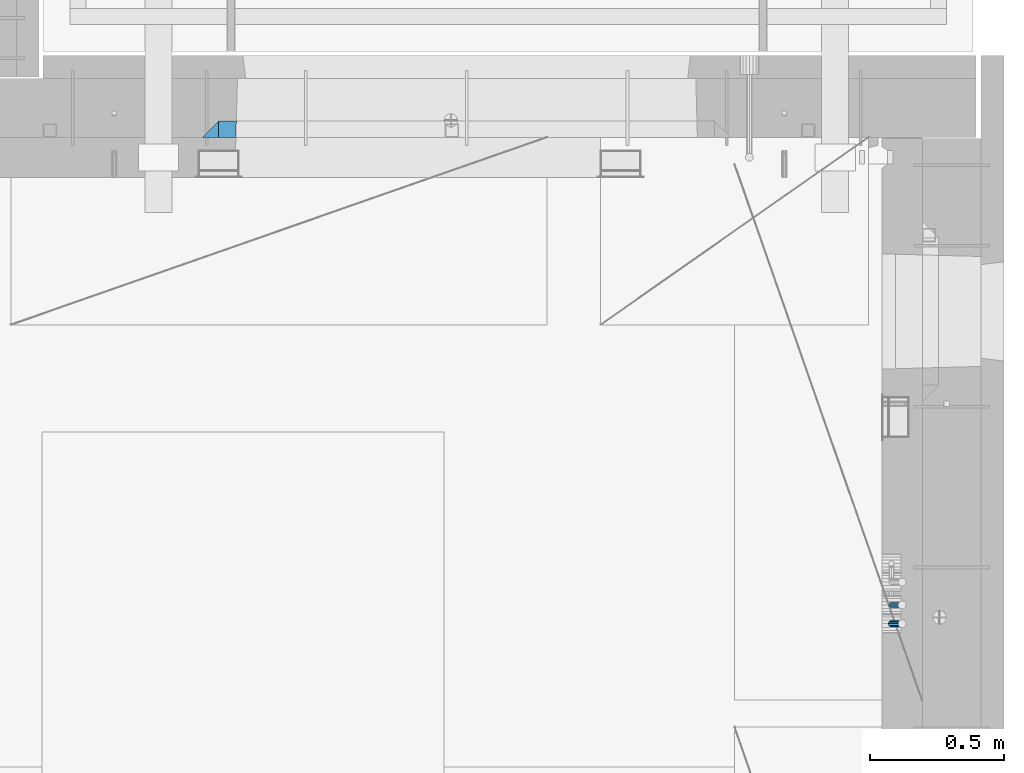
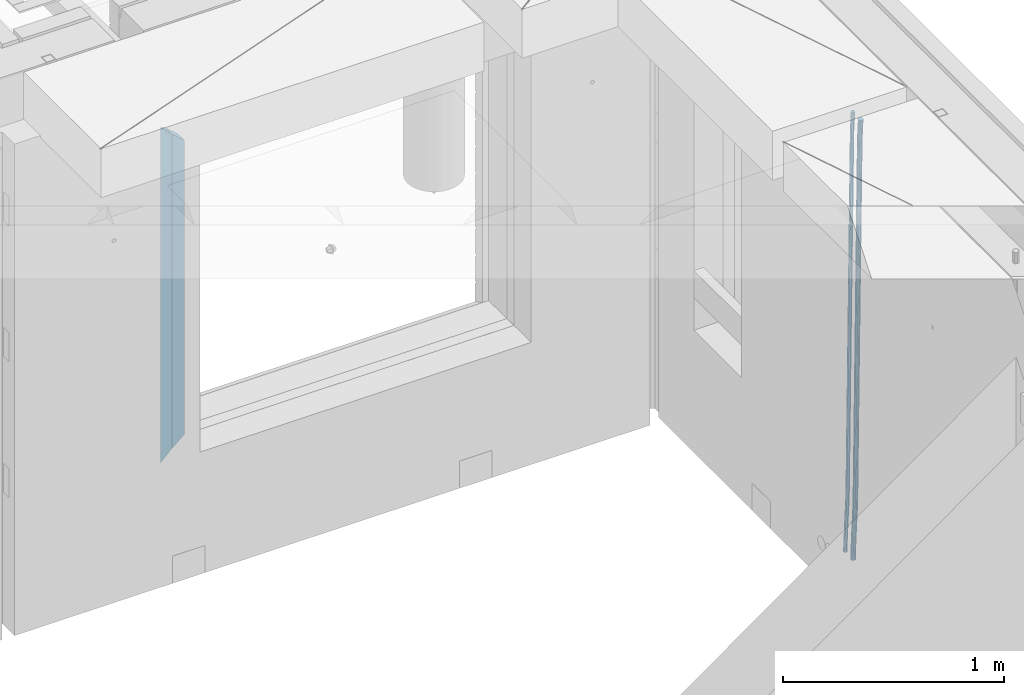
# One storey, part 127 of 334: 4 beams, 2 elements without a shape of their own.
"""IFC2X3 building model written with IfcOpenShell, lengths in millimetres."""

from ifc_helpers import new_model, si_unit, frame, origin_with_axes, place, context, subcontext, project, spatial, faceted_brep, material, type_object, element, aggregate, save


model = new_model("IFC2X3")

# Units and contexts
model_context = context("Model", 3, precision=1e-05, world=origin_with_axes())
body_context = subcontext(model_context, "Body", "Model", "MODEL_VIEW")
ifc_project = project(units=[si_unit("LENGTHUNIT", "METRE", prefix="MILLI"), si_unit("AREAUNIT", "SQUARE_METRE"), si_unit("VOLUMEUNIT", "CUBIC_METRE"), si_unit("MASSUNIT", "GRAM", prefix="KILO"), si_unit("TIMEUNIT", "SECOND"), si_unit("PLANEANGLEUNIT", "RADIAN"), si_unit("SOLIDANGLEUNIT", "STERADIAN"), si_unit("THERMODYNAMICTEMPERATUREUNIT", "DEGREE_CELSIUS"), si_unit("LUMINOUSINTENSITYUNIT", "LUMEN")], contexts=[model_context])

# Site, building, storey
site_placement = place(None, origin_with_axes())
site = spatial("IfcSite", under=ifc_project, at=site_placement, CompositionType="ELEMENT")
building_placement = place(site_placement, origin_with_axes())
building = spatial("IfcBuilding", under=site, at=building_placement, CompositionType="ELEMENT")
storey_placement = place(building_placement, origin_with_axes())
storey = spatial("IfcBuildingStorey", under=building, at=storey_placement, Name="3", CompositionType="ELEMENT", Elevation=0.0)

# Assembly, beams
assembly_1_placement = place(storey_placement, origin_with_axes())
assembly_1 = element("IfcElementAssembly", 1, at=assembly_1_placement, inside=storey, AssemblyPlace="NOTDEFINED", PredefinedType="REINFORCEMENT_UNIT")
ifc_material_1 = material()
beam_type_1 = type_object("IfcBeamType", Name="D20", PredefinedType="NOTDEFINED")
beam_1_placement = place(assembly_1_placement, frame((34944.9999977209, 18835.0002441367, 87990.0), z_axis=(0.999642804629538, 0.000205762999925497, -0.0267249099901003), x_axis=(0.0267249109941254, -4.30000210532798e-08, 0.999642825779465)))
beam_1 = element("IfcBeam", 2, at=beam_1_placement, type_object=beam_type_1, material=ifc_material_1, Name="JM20", ObjectType="D20", context=body_context, shape_type="Brep", body=[
    faceted_brep([(0.0, -10.0, 0.0), (-4.19531716033816e-08, -7.07106781186667, -7.07106781187031), (60.4266690400545, -7.0710677960451, -7.07106780570757), (60.4266690441291, -9.99999998418934, 6.15546014159918e-09), (0.0, 0.0, -10.0), (60.426669036824, 1.58106558956206e-08, -9.99999999384454), (4.196772351861e-08, 7.07106781186303, -7.07106781186667), (60.4266690363438, 7.07106782768096, -7.07106780570757), (0.0, 10.0, 0.0), (60.4266690388904, 10.0000000158179, 6.15182216279209e-09), (4.196772351861e-08, 7.07106781185939, 7.07106781185939), (60.4266690429649, 7.07106782768096, 7.07106781802577), (0.0, 0.0, 10.0), (60.4266690461809, 1.58179318532348e-08, 10.0000000061555), (-4.19531716033816e-08, -7.07106781187031, 7.07106781185939), (60.4266690466611, -7.07106779605238, 7.07106781802213), (61.0378400410118, -7.07106779588503, -7.07106780564936), (60.991799419251, -9.99999998403655, 6.21366780251265e-09), (61.0569027789461, 1.5985278878361e-08, -9.99999999378269), (61.0378209396877, 7.07106782784831, -7.07106780564936), (60.9917724058905, 10.0000000159635, 6.21366780251265e-09), (60.9457317841297, 7.07106782781193, 7.0710678180767), (60.9266690461809, 1.59488990902901e-08, 10.0000000062028), (60.9457508854539, -7.07106779591413, 7.0710678180767), (61.6489592143771, -7.07106614513759, -7.06310863441468), (61.5568818710308, -9.9999984576425, 0.00735959856683621), (61.6870830769039, 1.71821739058942e-06, -9.99179257185824), (61.6489210170112, 7.07106947854481, -7.06310888312146), (61.556827851804, 10.0000015422847, 0.00735924683976918), (61.4647505084577, 7.07106922979438, 7.07782747982128), (61.4266266459163, 1.36643211590126e-06, 10.0065114172685), (61.464788705809, -7.07106639389531, 7.07782772852806), (176.543135720174, -7.07075579406956, -5.56673531796696), (176.451058376813, -9.99968810657447, 1.50373291501455), (176.581259582701, 0.000312069292704109, -8.49541925541052), (176.543097522794, 7.07137982961285, -5.56673556667374), (176.451004357587, 10.00031189336, 1.50373256329476), (176.35892701424, 7.07137958085514, 8.57420079627263), (176.320803151699, 0.000311717507429421, 11.5028847337162), (176.358965211621, -7.07075604281999, 8.57420104497578), (177.098753836006, -7.07075429323595, -5.55949898843028), (176.98362511232, -9.99968666800123, 1.510669025065), (177.146421932586, 0.000313595905026887, -8.48805862247536), (177.098706077581, 7.07138133041735, -5.55949936166144), (176.983557571715, 10.0003133318824, 1.51066849724157), (176.868428848029, 7.07138095712435, 8.58083651073321), (176.820760751449, 0.000313067976094317, 11.5093961447819), (176.868476606425, -7.07075466652896, 8.58083688396073), (177.654312950661, -7.07075204110879, -5.54863964998367), (177.516135294456, -9.99968450931192, 1.52107783331303), (177.711524267797, 0.000315886711177882, -8.47701274570863), (177.654255632195, 7.07138358250813, -5.54864021007961), (177.516054233929, 10.0003154905207, 1.5210770412159), (177.377876577739, 7.0713830223176, 8.59079452451624), (177.320665260588, 0.000315094497636892, 11.5191676202448), (177.377933896176, -7.07075260129932, 8.59079508461218), (299.436796249574, -7.07025836271714, -3.1681962331204), (299.298618593355, -9.99919083092027, 3.90152125031091), (299.494007566798, 0.000809565110102994, -6.09656932889993), (299.436738931283, 7.07187726089978, -3.16819679320906), (299.298537533061, 10.0008091689197, 3.90152045822106), (299.160359876842, 7.07187670072017, 10.9712379416487), (299.103148559603, 0.000808772889286047, 13.8996110374392), (299.160417195119, -7.07025892290039, 10.9712385017483), (299.98743051647, -7.07025613056248, -3.15743315966392), (299.971788958996, -9.99918809853989, 3.91467979818117), (299.993912075952, 0.000811591617093654, -6.08679785393178), (299.987423933868, 7.07187949325817, -3.1574327280432), (299.971753863239, 10.0008119014747, 3.91467990454839), (299.95611230444, 7.07187992653053, 10.9867922621015), (299.949630744944, 0.000812204350950196, 13.9161569563694), (299.956118887014, -7.07025569729012, 10.9867918304735), (300.538107039494, -7.07025785017686, -3.16575821840888), (300.644985195438, -9.99919020432935, 3.90450175465594), (300.493854948218, 0.000810030429420294, -6.09435592770024), (300.538151196495, 7.071877773491, -3.16575855385963), (300.645047642858, 10.0008097955724, 3.90450128024895), (300.751925798773, 7.07187744142357, 10.9747612533101), (300.796177890064, 0.000809560813650023, 13.9033589625978), (300.751881641787, -7.07025818224065, 10.9747615887682), (2293.36490490142, -7.07648090940347, -33.2930642912361), (2293.47178305736, -10.0054132635523, -26.2228043181785), (2293.32065281013, -0.00541302880083094, -36.2216620005347), (2293.36494905842, 7.06565471425711, -33.2930646266868), (2293.47184550477, 9.99458673634581, -26.2228047925819), (2293.57872366071, 7.06565438219332, -19.1525448195243), (2293.62297575199, -0.00541349841296324, -16.2239471102366), (2293.57867950371, -7.0764812414709, -19.1525444840736), (2294.0658245362, -7.07648309818615, -33.3036607065333), (2294.05312277409, -10.0054150789219, -26.2315929392535), (2294.10928714235, -0.00541549149056664, -36.2335844756526), (2294.15805078732, 7.06565223761572, -33.3050546393533), (2294.18355038921, 9.99458451388637, -26.2335642579346), (2294.17084862708, 7.06565253314329, -19.1614964906439), (2294.12738602093, -0.00541507354500936, -16.2315727215355), (2294.07862237596, -7.07648280265857, -19.1601025578348), (2294.76670261032, -7.08562269121467, -33.294332712383), (2294.63442802057, -10.0129954178956, -26.2238563411993), (2294.89787471293, -0.0156988342423574, -36.2230891548279), (2294.95110548967, 7.05531064255774, -33.2944998654275), (2294.89521307347, 9.98530428734011, -26.2240927312887), (2294.76293848372, 7.0579315606592, -19.1536163601049), (2294.63176638114, -0.0119922963167483, -16.2248599176673), (2294.57853560438, -7.08300177311321, -19.1534492070678), (2316.52657204497, -7.36937582653991, -33.0047303660212), (2316.39429745522, -10.2967485532172, -25.9342539948302), (2316.65774414754, -0.299451969567599, -35.9334868084661), (2316.7109749243, 6.7715575072325, -33.0048975190657), (2316.65508250811, 9.70155115201487, -25.9344903849269), (2316.52280791836, 6.7741784253376, -18.8640140137468), (2316.39163581574, -0.295745431634714, -15.9352575713092), (2316.33840503903, -7.36675490843481, -18.863846860706), (2317.16202064224, -7.37766220584308, -32.9962731735213), (2317.05438744847, -10.3053562613532, -25.9254688497131), (2317.23607125619, -0.306993473008333, -35.925789846493), (2317.23316144495, 6.76474808850253, -32.9979477328052), (2317.15499573652, 9.6950321815566, -25.9278370341635), (2317.04736254275, 6.7673381260538, -18.8570327103698), (2316.97331192881, -0.303330606784584, -15.9275160373909), (2316.97622174003, -7.37507216829545, -18.8553581510787), (2317.79752306276, -7.37578610372293, -32.9880110666527), (2317.71453320107, -10.3033876998124, -25.9168792378296), (2317.81444760226, -0.305295583297266, -35.918287695793), (2317.75539265381, 6.76628640723357, -32.9911928173897), (2317.65495180529, 9.69652304524061, -25.9213789128698), (2317.5719619436, 6.76892144914746, -18.8502470840467), (2317.55503740412, -0.301569071270933, -15.9199704549137), (2317.61409235255, -7.3731510618054, -18.847065333317), (2417.8183084176, -7.07752398473531, -31.6906369377139), (2417.73531855589, -10.0051255808248, -24.6195051088798), (2417.83523295709, -0.007033464313281, -34.6209135668432), (2417.77617800863, 7.06454852621755, -31.6938186884508), (2417.67573716014, 9.99478516423187, -24.6240047839383), (2417.59274729842, 7.06718356813872, -17.5528729551006), (2417.57582275895, -0.00330695228694822, -14.6225963259749), (2417.6348777074, -7.07488894281778, -17.5496912043673)], [[[0, 1, 2, 3]], [[1, 4, 5, 2]], [[4, 6, 7, 5]], [[6, 8, 9, 7]], [[8, 10, 11, 9]], [[10, 12, 13, 11]], [[12, 14, 15, 13]], [[14, 0, 3, 15]], [[14, 12, 10, 8, 6, 4, 1, 0]], [[3, 2, 16, 17]], [[2, 5, 18, 16]], [[5, 7, 19, 18]], [[7, 9, 20, 19]], [[9, 11, 21, 20]], [[11, 13, 22, 21]], [[13, 15, 23, 22]], [[15, 3, 17, 23]], [[17, 16, 24, 25]], [[16, 18, 26, 24]], [[18, 19, 27, 26]], [[19, 20, 28, 27]], [[20, 21, 29, 28]], [[21, 22, 30, 29]], [[22, 23, 31, 30]], [[23, 17, 25, 31]], [[25, 24, 32, 33]], [[24, 26, 34, 32]], [[26, 27, 35, 34]], [[27, 28, 36, 35]], [[28, 29, 37, 36]], [[29, 30, 38, 37]], [[30, 31, 39, 38]], [[31, 25, 33, 39]], [[33, 32, 40, 41]], [[32, 34, 42, 40]], [[34, 35, 43, 42]], [[35, 36, 44, 43]], [[36, 37, 45, 44]], [[37, 38, 46, 45]], [[38, 39, 47, 46]], [[39, 33, 41, 47]], [[41, 40, 48, 49]], [[40, 42, 50, 48]], [[42, 43, 51, 50]], [[43, 44, 52, 51]], [[44, 45, 53, 52]], [[45, 46, 54, 53]], [[46, 47, 55, 54]], [[47, 41, 49, 55]], [[49, 48, 56, 57]], [[48, 50, 58, 56]], [[50, 51, 59, 58]], [[51, 52, 60, 59]], [[52, 53, 61, 60]], [[53, 54, 62, 61]], [[54, 55, 63, 62]], [[55, 49, 57, 63]], [[57, 56, 64, 65]], [[56, 58, 66, 64]], [[58, 59, 67, 66]], [[59, 60, 68, 67]], [[60, 61, 69, 68]], [[61, 62, 70, 69]], [[62, 63, 71, 70]], [[63, 57, 65, 71]], [[65, 64, 72, 73]], [[64, 66, 74, 72]], [[66, 67, 75, 74]], [[67, 68, 76, 75]], [[68, 69, 77, 76]], [[69, 70, 78, 77]], [[70, 71, 79, 78]], [[71, 65, 73, 79]], [[73, 72, 80, 81]], [[72, 74, 82, 80]], [[74, 75, 83, 82]], [[75, 76, 84, 83]], [[76, 77, 85, 84]], [[77, 78, 86, 85]], [[78, 79, 87, 86]], [[79, 73, 81, 87]], [[81, 80, 88, 89]], [[80, 82, 90, 88]], [[82, 83, 91, 90]], [[83, 84, 92, 91]], [[84, 85, 93, 92]], [[85, 86, 94, 93]], [[86, 87, 95, 94]], [[87, 81, 89, 95]], [[89, 88, 96, 97]], [[88, 90, 98, 96]], [[90, 91, 99, 98]], [[91, 92, 100, 99]], [[92, 93, 101, 100]], [[93, 94, 102, 101]], [[94, 95, 103, 102]], [[95, 89, 97, 103]], [[97, 96, 104, 105]], [[96, 98, 106, 104]], [[98, 99, 107, 106]], [[99, 100, 108, 107]], [[100, 101, 109, 108]], [[101, 102, 110, 109]], [[102, 103, 111, 110]], [[103, 97, 105, 111]], [[105, 104, 112, 113]], [[104, 106, 114, 112]], [[106, 107, 115, 114]], [[107, 108, 116, 115]], [[108, 109, 117, 116]], [[109, 110, 118, 117]], [[110, 111, 119, 118]], [[111, 105, 113, 119]], [[113, 112, 120, 121]], [[112, 114, 122, 120]], [[114, 115, 123, 122]], [[115, 116, 124, 123]], [[116, 117, 125, 124]], [[117, 118, 126, 125]], [[118, 119, 127, 126]], [[119, 113, 121, 127]], [[121, 120, 128, 129]], [[120, 122, 130, 128]], [[122, 123, 131, 130]], [[123, 124, 132, 131]], [[124, 125, 133, 132]], [[125, 126, 134, 133]], [[126, 127, 135, 134]], [[127, 121, 129, 135]], [[130, 131, 132, 133, 134, 135, 129, 128]]]),
])
beam_type_2 = type_object("IfcBeamType", Name="D25", PredefinedType="NOTDEFINED")
beam_2_placement = place(assembly_1_placement, frame((34944.9999977209, 18765.0002441367, 87990.0), z_axis=(0.999642804629538, 0.000205762999925497, -0.0267249099901003), x_axis=(0.0267249109941254, -4.30000210532798e-08, 0.999642825779465)))
beam_2 = element("IfcBeam", 3, at=beam_2_placement, type_object=beam_type_2, material=ifc_material_1, Name="JM25", ObjectType="D25", context=body_context, shape_type="Brep", body=[
    faceted_brep([(-7.41420080885291e-08, -12.5, -3.63797880709171e-12), (-6.42030499875546e-08, -10.8253175473074, -6.25000000000364), (60.4103898235917, -10.8253175318459, -6.2499999938409), (60.4103898269532, -12.4999999845422, 6.16273609921336e-09), (-3.70782800018787e-08, -6.25000000000364, -10.8253175473074), (60.4103898202884, -6.24999998454587, -10.8253175411446), (-1.45519152283669e-11, -3.63797880709171e-12, -12.5), (60.4103898179019, 1.54577719513327e-08, -12.4999999938373), (3.70637280866504e-08, 6.25, -10.8253175473074), (60.410389817087, 6.25000001545777, -10.825317541141), (6.42030499875546e-08, 10.8253175473001, -6.25000000000364), (60.410389818062, 10.8253175627578, -6.24999999383726), (7.41420080885291e-08, 12.4999999999927, 0.0), (60.4103898205503, 12.5000000154541, 6.16273609921336e-09), (6.42176019027829e-08, 10.8253175473001, 6.24999999999636), (60.4103898238973, 10.8253175627651, 6.2500000061591), (3.70928319171071e-08, 6.24999999999636, 10.8253175473037), (60.4103898272151, 6.25000001546141, 10.8253175534664), (1.45519152283669e-11, -3.63797880709171e-12, 12.4999999999964), (60.4103898296162, 1.54541339725256e-08, 12.5000000061591), (-3.7049176171422e-08, -6.25000000000364, 10.8253175473001), (60.4103898304165, -6.24999998454587, 10.8253175534701), (-6.41884980723262e-08, -10.8253175473074, 6.25), (60.4103898294561, -10.8253175318459, 6.25000000616637), (61.0324985728803, -10.8253175316895, -6.24999999377542), (60.991802792938, -12.4999999843931, 6.22458173893392e-09), (61.0622854283865, -6.24999998437852, -10.8253175410755), (61.0731819955545, 1.5628756955266e-08, -12.4999999937718), (61.0622685480339, 6.25000001562512, -10.8253175410791), (61.032469335245, 10.8253175629216, -6.24999999377178), (60.9917690322181, 12.5000000156033, 6.22458173893392e-09), (60.9510732522613, 10.8253175629034, 6.25000000621731), (60.9212863967696, 6.25000001558874, 10.8253175535247), (60.9103898296162, 1.55814632307738e-08, 12.5000000062137), (60.9213032771368, -6.24999998441126, 10.8253175535174), (60.9511024898966, -10.8253175317113, 6.25000000621731), (61.6545545670233, -10.8253158516927, -6.24189838219536), (61.573166454793, -12.499998414296, 0.00757164385504439), (61.7141257553885, -6.24999822394238, -10.8168280205282), (61.7359179680789, 1.80548886419274e-06, -12.491368569139), (61.7140919992817, 6.25000177601396, -10.8168282403167), (61.6544960997562, 10.8253192428383, -6.2418987628771), (61.5730989426083, 12.5000015856094, 0.0075712042817031), (61.4917108303925, 10.8253190230062, 6.25704123032847), (61.4321396420273, 6.25000139525582, 10.8319708686649), (61.4103474293224, 1.36582457344048e-06, 12.5065114172721), (61.4321733981196, -6.24999860470052, 10.8319710884571), (61.4917692976451, -10.8253160715249, 6.25704161101385), (176.524302641745, -10.8250056210964, -4.74584321979273), (176.442914529529, -12.4996881836996, 1.50362680625403), (176.583873830095, -6.24968799334965, -9.3207728581292), (176.605666042786, 0.000312036081595579, -10.9953134067364), (176.583840074018, 6.25031200660669, -9.32077307791769), (176.524244174492, 10.8256294734347, -4.74584360047811), (176.44284701733, 12.5003118162058, 1.50362636668069), (176.361458905099, 10.8256292535989, 7.75309639272746), (176.301887716749, 6.25031162585219, 12.3280260310676), (176.280095504058, 0.000311596420942806, 14.0025665796711), (176.301921472827, -6.24968837410415, 12.3280262508561), (176.361517372367, -10.8250058409321, 7.75309677341284), (177.085397012124, -10.8250041057399, -4.73853556792164), (176.983633547483, -12.4996867233749, 1.51066909103247), (177.159881729676, -6.24968643771717, -9.31327097355097), (177.187129580227, 0.000313606451527448, -10.987740468332), (177.159839524218, 6.25031356221734, -9.31327130338468), (177.085323910098, 10.8256309887511, -4.73853613920801), (176.983549136537, 12.5003132764905, 1.51066843136869), (176.881785671867, 10.8256306588555, 7.7598730903228), (176.80730095433, 6.25031299082912, 12.3346084959521), (176.780053103794, 0.000312946667690994, 14.0090779907332), (176.807343159802, -6.2496870091054, 12.3346088257895), (176.881858773908, -10.8250044356355, 7.7598736616128), (177.646431799818, -10.8250018318176, -4.72756919822132), (177.524295146417, -12.4996845320202, 1.52123723245313), (177.735828462886, -6.24968410334986, -9.30201312475765), (177.768531371941, 0.00031596292683389, -10.9763759912421), (177.735777808921, 6.25031589654827, -9.30201361973741), (177.646344064575, 10.8256332626152, -4.72757005553649), (177.524193838486, 12.5003154677688, 1.52123624250817), (177.402057185071, 10.8256327675663, 7.77004267317898), (177.312660521988, 6.2503150390985, 12.3444865997226), (177.279957612933, 0.00031497282179771, 14.0188494661961), (177.312711175953, -6.24968496079964, 12.3444870946951), (177.402144920314, -10.8250023268702, 7.77004353049415), (299.377443161706, -10.8245084454466, -2.34813158632096), (299.255306508276, -12.4991911456491, 3.90067484435349), (299.466839824803, -6.24919071697514, -6.92257551286093), (299.499542733873, 0.0008093492979242, -8.59693837933446), (299.466789170867, 6.250809282923, -6.92257600783341), (299.377355426492, 10.8261266489935, -2.34813244364341), (299.255205200388, 12.5008088541435, 3.90067385440125), (299.133068546944, 10.826126153941, 10.1494802850757), (299.043671883861, 6.25080842546959, 14.7239242116229), (299.010968974762, 0.000808359200163977, 16.3982870780892), (299.043722537797, -6.24919157442127, 14.7239247065918), (299.133156282158, -10.8245089404954, 10.1494811423981), (299.98561436501, -10.8245059804758, -2.33624385599614), (299.97179243555, -12.4991882411778, 3.91467976726199), (299.995742293278, -6.24918857328521, -6.91223722345239), (299.999447243041, 0.000811375455668895, -8.58716690387519), (299.995736475976, 6.25081142679483, -6.91223684201032), (299.985604289133, 10.8261291142808, -2.33624319533556), (299.971750386685, 12.5008117588586, 3.91467993563856), (299.957928457196, 10.8261294971744, 10.1656035610831), (299.947800528913, 6.25081208998381, 14.7415969285394), (299.944095579151, 0.00081214124293183, 16.4165266089549), (299.947806346216, -6.24918791008895, 14.7415965471009), (299.957938533058, -10.8245055975785, 10.1656029004225), (300.593832239858, -10.8245078794353, -2.34543881707941), (300.688302931099, -12.4991904788549, 3.90384712594823), (300.524685350189, -6.24919022474205, -6.92023371784308), (300.499390115292, 0.000809814544481924, -8.59472497713432), (300.524724372954, 6.25080977519247, -6.92023401429469), (300.593899829313, 10.8261272150703, -2.34543933054374), (300.688380976673, 12.5008095210287, 3.90384653304136), (300.782851667915, 10.8261269216127, 10.1531324760799), (300.851998557599, 6.25080926691589, 14.7279273768363), (300.877293792495, 0.000809227632998955, 16.4024186361276), (300.851959534804, -6.24919073302226, 14.7279276732806), (300.782784078474, -10.8245081728965, 10.153132989537), (2293.32930409742, -10.8307295605009, -32.4713622331001), (2293.42377478865, -12.5054121599169, -26.2220762900724), (2293.26015720774, -6.2554119058077, -37.0461571338565), (2293.23486197284, -0.00541186651753378, -38.7206483931477), (2293.26019623051, 6.24458809413409, -37.0461574303008), (2293.32937168686, 10.8199055340046, -32.4713627465644), (2293.42385283421, 12.4945878399631, -26.2220768829684), (2293.51832352545, 10.8199052405434, -19.972790939948), (2293.58747041514, 6.24458758585388, -15.3979960391844), (2293.61276565003, -0.00541245343265473, -13.7235047798931), (2293.58743139236, -6.25541241408428, -15.3979957427327), (2293.51825593603, -10.8307298539585, -19.9727904264691), (2294.0420846676, -10.8307317859326, -32.4821379598216), (2294.03681932652, -12.5054140739521, -26.2313442200393), (2294.06778164886, -6.2554144273563, -37.0583666982457), (2294.10702478497, -0.00541458957013674, -38.7338336404937), (2294.14929890928, 6.24458531819619, -37.0595987724118), (2294.18327670435, 10.8199028679592, -32.4842719748667), (2294.1998538474, 12.4945854171456, -26.2338083683717), (2294.19458850632, 10.819903129126, -19.9830146285858), (2294.16889152506, 6.24458577054975, -15.4067858901581), (2294.12964838895, -0.0054140672327776, -13.7313189479173), (2294.08737426462, -6.2554139749991, -15.4055538159919), (2294.05339646956, -10.8307315247621, -19.9808806135297), (2294.75482297382, -10.84002603931, -32.4726521173216), (2294.64982751427, -12.513407826169, -26.2231856868602), (2294.87535820232, -6.26594539088183, -37.0476186524102), (2294.97913588268, -0.0167870967634371, -38.7222267036377), (2295.0383488692, 6.23299192477134, -37.0477663960555), (2295.03713108998, 10.8087684320271, -32.4729080168181), (2294.97580884799, 12.4844668051373, -26.2234811741473), (2294.87081338844, 10.8110850182784, -19.9740147436787), (2294.7502781599, 6.23700436985018, -15.3990482086047), (2294.64650047956, -0.0121539242718427, -13.7244401573698), (2294.58728749304, -6.26193294580662, -15.3989004649666), (2294.58850527227, -10.8377094530588, -19.9737588441894), (2316.44667268227, -11.1228921988077, -32.1839550346631), (2316.34167722271, -12.7962739856739, -25.9344886042054), (2316.56720791078, -6.54881155039038, -36.7589215697517), (2316.67098559113, -0.299653256264719, -38.4335296209792), (2316.73019857766, 5.95012576527006, -36.759069313397), (2316.72898079845, 10.5259022725259, -32.1842109341669), (2316.66765855643, 12.2016006456361, -25.9347840914961), (2316.56266309689, 10.5282188587698, -19.6853176610275), (2316.44212786836, 5.95413821035254, -15.1103511259389), (2316.33835018802, -0.295020083769487, -13.4357430747186), (2316.27913720149, -6.54479910530426, -15.1102033823008), (2316.28035498071, -11.1205756125637, -19.685061761531), (2317.13234804722, -11.1318335458927, -32.1748293731798), (2317.04181141085, -12.8054038787741, -25.9251705100723), (2317.2154741603, -6.5572650749491, -36.7502937866229), (2317.26891617525, -0.307450393454928, -38.4255717558117), (2317.27835434731, 5.94297770185585, -36.7517739018112), (2317.24125972588, 10.5192220504723, -32.1773930078925), (2317.16757178486, 12.1950816748285, -25.9281307404563), (2317.0770351485, 10.5215113419545, -19.6784718773561), (2316.99390903539, 5.94694287101083, -15.1030074639057), (2316.94046702047, -0.302871810494253, -13.4277294947169), (2316.9310288484, -6.55329990579412, -15.1015273487101), (2316.96812346982, -11.1295442544142, -19.6759082426288), (2317.81808136747, -11.1298054502913, -32.1659056455355), (2317.74200467508, -12.803315894289, -25.9160547315114), (2317.86379538118, -6.55536082026447, -36.7418676070083), (2317.8668976831, -0.305700748642266, -38.417815303761), (2317.82655701396, 5.94458339541234, -36.7446799039099), (2317.75358262347, 10.5207330230332, -32.1707766866384), (2317.66752794063, 12.1965725370646, -25.9216793252963), (2317.59145124823, 10.5230620930706, -19.6718284112721), (2317.54573723453, 5.94861746304377, -15.0958664497994), (2317.54263493262, -0.301042608574789, -13.4199187530394), (2317.58297560175, -6.55132675263303, -15.0930541529051), (2317.65594999224, -11.1274763802539, -19.6669573701693), (2417.81884292323, -10.831603083323, -30.8687911350135), (2417.74276623082, -12.505113527317, -24.618940220982), (2417.86455693691, -6.25715845329614, -35.4447530964935), (2417.86765923884, -0.00749838167394046, -37.1207007932499), (2417.82731856969, 6.24278576237703, -35.4475653933878), (2417.75434417921, 10.8189353900088, -30.8736621761236), (2417.66828949639, 12.494774904033, -24.6245648147851), (2417.59221280397, 10.8212644600353, -18.3747139007501), (2417.54649879028, 6.2468198300121, -13.79875193927), (2417.54339648837, -0.00284024161010166, -12.1228042425173), (2417.5837371575, -6.25312438566107, -13.795939642383), (2417.65671154798, -10.8292740132893, -18.3698428596399)], [[[0, 1, 2, 3]], [[1, 4, 5, 2]], [[4, 6, 7, 5]], [[6, 8, 9, 7]], [[8, 10, 11, 9]], [[10, 12, 13, 11]], [[12, 14, 15, 13]], [[14, 16, 17, 15]], [[16, 18, 19, 17]], [[18, 20, 21, 19]], [[20, 22, 23, 21]], [[22, 0, 3, 23]], [[22, 20, 18, 16, 14, 12, 10, 8, 6, 4, 1, 0]], [[3, 2, 24, 25]], [[2, 5, 26, 24]], [[5, 7, 27, 26]], [[7, 9, 28, 27]], [[9, 11, 29, 28]], [[11, 13, 30, 29]], [[13, 15, 31, 30]], [[15, 17, 32, 31]], [[17, 19, 33, 32]], [[19, 21, 34, 33]], [[21, 23, 35, 34]], [[23, 3, 25, 35]], [[25, 24, 36, 37]], [[24, 26, 38, 36]], [[26, 27, 39, 38]], [[27, 28, 40, 39]], [[28, 29, 41, 40]], [[29, 30, 42, 41]], [[30, 31, 43, 42]], [[31, 32, 44, 43]], [[32, 33, 45, 44]], [[33, 34, 46, 45]], [[34, 35, 47, 46]], [[35, 25, 37, 47]], [[37, 36, 48, 49]], [[36, 38, 50, 48]], [[38, 39, 51, 50]], [[39, 40, 52, 51]], [[40, 41, 53, 52]], [[41, 42, 54, 53]], [[42, 43, 55, 54]], [[43, 44, 56, 55]], [[44, 45, 57, 56]], [[45, 46, 58, 57]], [[46, 47, 59, 58]], [[47, 37, 49, 59]], [[49, 48, 60, 61]], [[48, 50, 62, 60]], [[50, 51, 63, 62]], [[51, 52, 64, 63]], [[52, 53, 65, 64]], [[53, 54, 66, 65]], [[54, 55, 67, 66]], [[55, 56, 68, 67]], [[56, 57, 69, 68]], [[57, 58, 70, 69]], [[58, 59, 71, 70]], [[59, 49, 61, 71]], [[61, 60, 72, 73]], [[60, 62, 74, 72]], [[62, 63, 75, 74]], [[63, 64, 76, 75]], [[64, 65, 77, 76]], [[65, 66, 78, 77]], [[66, 67, 79, 78]], [[67, 68, 80, 79]], [[68, 69, 81, 80]], [[69, 70, 82, 81]], [[70, 71, 83, 82]], [[71, 61, 73, 83]], [[73, 72, 84, 85]], [[72, 74, 86, 84]], [[74, 75, 87, 86]], [[75, 76, 88, 87]], [[76, 77, 89, 88]], [[77, 78, 90, 89]], [[78, 79, 91, 90]], [[79, 80, 92, 91]], [[80, 81, 93, 92]], [[81, 82, 94, 93]], [[82, 83, 95, 94]], [[83, 73, 85, 95]], [[85, 84, 96, 97]], [[84, 86, 98, 96]], [[86, 87, 99, 98]], [[87, 88, 100, 99]], [[88, 89, 101, 100]], [[89, 90, 102, 101]], [[90, 91, 103, 102]], [[91, 92, 104, 103]], [[92, 93, 105, 104]], [[93, 94, 106, 105]], [[94, 95, 107, 106]], [[95, 85, 97, 107]], [[97, 96, 108, 109]], [[96, 98, 110, 108]], [[98, 99, 111, 110]], [[99, 100, 112, 111]], [[100, 101, 113, 112]], [[101, 102, 114, 113]], [[102, 103, 115, 114]], [[103, 104, 116, 115]], [[104, 105, 117, 116]], [[105, 106, 118, 117]], [[106, 107, 119, 118]], [[107, 97, 109, 119]], [[109, 108, 120, 121]], [[108, 110, 122, 120]], [[110, 111, 123, 122]], [[111, 112, 124, 123]], [[112, 113, 125, 124]], [[113, 114, 126, 125]], [[114, 115, 127, 126]], [[115, 116, 128, 127]], [[116, 117, 129, 128]], [[117, 118, 130, 129]], [[118, 119, 131, 130]], [[119, 109, 121, 131]], [[121, 120, 132, 133]], [[120, 122, 134, 132]], [[122, 123, 135, 134]], [[123, 124, 136, 135]], [[124, 125, 137, 136]], [[125, 126, 138, 137]], [[126, 127, 139, 138]], [[127, 128, 140, 139]], [[128, 129, 141, 140]], [[129, 130, 142, 141]], [[130, 131, 143, 142]], [[131, 121, 133, 143]], [[133, 132, 144, 145]], [[132, 134, 146, 144]], [[134, 135, 147, 146]], [[135, 136, 148, 147]], [[136, 137, 149, 148]], [[137, 138, 150, 149]], [[138, 139, 151, 150]], [[139, 140, 152, 151]], [[140, 141, 153, 152]], [[141, 142, 154, 153]], [[142, 143, 155, 154]], [[143, 133, 145, 155]], [[145, 144, 156, 157]], [[144, 146, 158, 156]], [[146, 147, 159, 158]], [[147, 148, 160, 159]], [[148, 149, 161, 160]], [[149, 150, 162, 161]], [[150, 151, 163, 162]], [[151, 152, 164, 163]], [[152, 153, 165, 164]], [[153, 154, 166, 165]], [[154, 155, 167, 166]], [[155, 145, 157, 167]], [[157, 156, 168, 169]], [[156, 158, 170, 168]], [[158, 159, 171, 170]], [[159, 160, 172, 171]], [[160, 161, 173, 172]], [[161, 162, 174, 173]], [[162, 163, 175, 174]], [[163, 164, 176, 175]], [[164, 165, 177, 176]], [[165, 166, 178, 177]], [[166, 167, 179, 178]], [[167, 157, 169, 179]], [[169, 168, 180, 181]], [[168, 170, 182, 180]], [[170, 171, 183, 182]], [[171, 172, 184, 183]], [[172, 173, 185, 184]], [[173, 174, 186, 185]], [[174, 175, 187, 186]], [[175, 176, 188, 187]], [[176, 177, 189, 188]], [[177, 178, 190, 189]], [[178, 179, 191, 190]], [[179, 169, 181, 191]], [[181, 180, 192, 193]], [[180, 182, 194, 192]], [[182, 183, 195, 194]], [[183, 184, 196, 195]], [[184, 185, 197, 196]], [[185, 186, 198, 197]], [[186, 187, 199, 198]], [[187, 188, 200, 199]], [[188, 189, 201, 200]], [[189, 190, 202, 201]], [[190, 191, 203, 202]], [[191, 181, 193, 203]], [[194, 195, 196, 197, 198, 199, 200, 201, 202, 203, 193, 192]]]),
])
aggregate(assembly_1, [beam_1, beam_2])

assembly_2_placement = place(storey_placement, origin_with_axes())
assembly_2 = element("IfcElementAssembly", 4, at=assembly_2_placement, inside=storey, AssemblyPlace="NOTDEFINED", PredefinedType="REINFORCEMENT_UNIT")
ifc_material_2 = material(Name="CONCRETE/C25/30")
beam_type_3 = type_object("IfcBeamType", PredefinedType="NOTDEFINED")
beam_3_placement = place(assembly_2_placement, frame((32405.0002457424, 20609.9951872276, 90175.0), z_axis=(1.0, 0.0, 0.0), x_axis=(0.0, 0.0, -1.0)))
beam_3 = element("IfcBeam", 5, at=beam_3_placement, type_object=beam_type_3, material=ifc_material_2, Name="SK", context=body_context, shape_type="Brep", body=[
    faceted_brep([(60.0000000000073, 30.0, 30.0), (0.0, -30.0, -30.0), (60.0000000000073, -30.0, 30.0), (1795.00000000001, 30.0, 30.0), (1855.0, -30.0, -30.0), (1795.00000000001, -30.0, 30.0)], [[[0, 1, 2]], [[3, 4, 1, 0]], [[4, 5, 2, 1]], [[5, 3, 0, 2]], [[5, 4, 3]]]),
])
beam_type_4 = type_object("IfcBeamType", PredefinedType="NOTDEFINED")
beam_4_placement = place(assembly_2_placement, frame((32470.0002457424, 20609.9951872276, 90115.0), z_axis=(1.0, 0.0, 0.0), x_axis=(0.0, 0.0, -1.0)))
beam_4 = element("IfcBeam", 6, at=beam_4_placement, type_object=beam_type_4, material=ifc_material_2, Name="SK", context=body_context, shape_type="Brep", body=[
    faceted_brep([(0.0, -30.0, -35.0), (54.9034748914273, -30.0, 29.0540540540533), (56.2934362811066, 30.0, 30.6756756756768), (0.0, 30.0, -35.0), (1678.70656371891, 30.0, 30.6756756756768), (1735.0, 30.0, -35.0), (1735.0, -30.0, -35.0), (1680.09652510857, -30.0, 29.0540540540533)], [[[0, 1, 2, 3]], [[3, 2, 4, 5]], [[5, 6, 0, 3]], [[1, 0, 6, 7]], [[2, 1, 7, 4]], [[6, 5, 4, 7]]]),
])
aggregate(assembly_2, [beam_3, beam_4])

save(model, "model.ifc")
